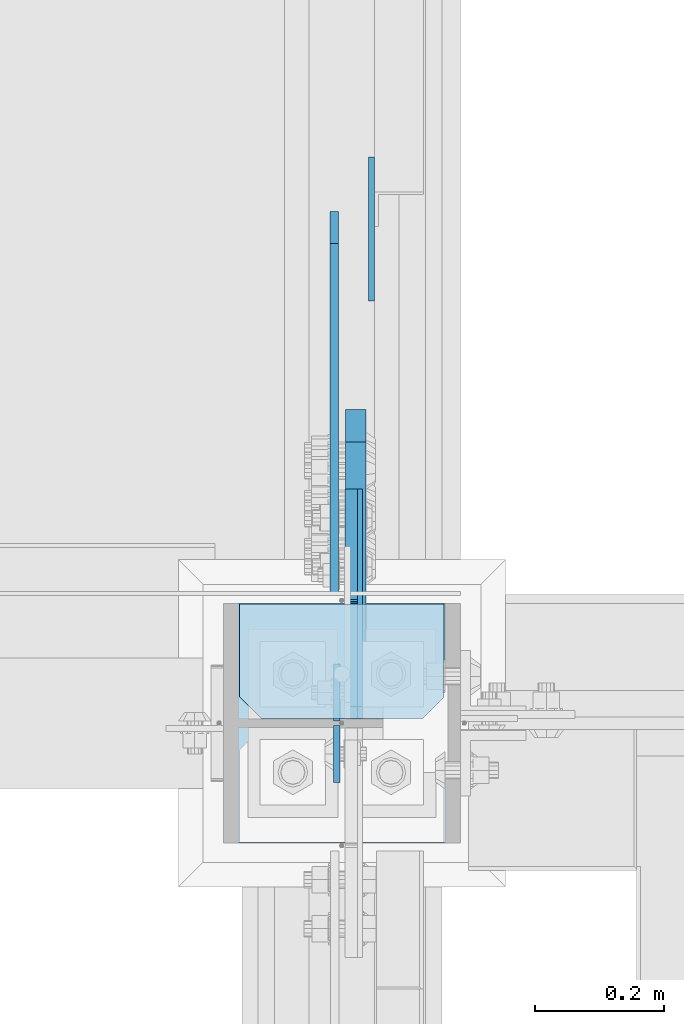
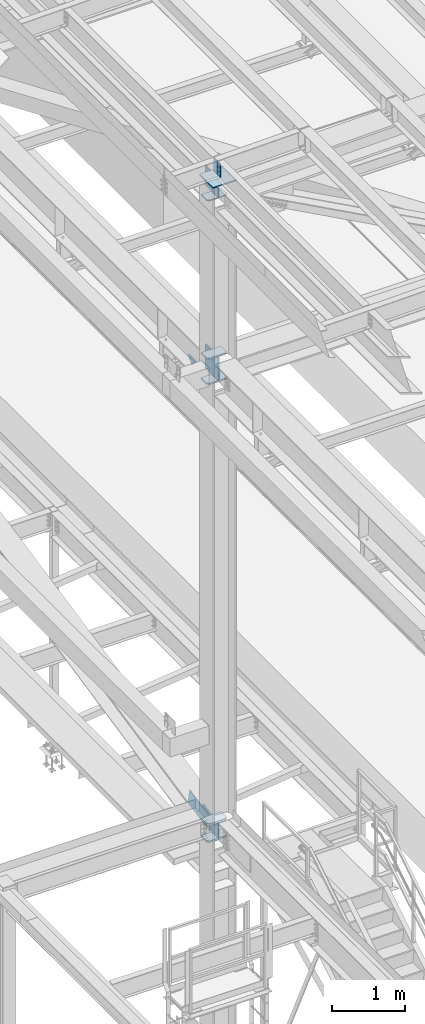
# One storey, part 3209 of 3843: 13 plates, 4 elements without a shape of their own.
"""IFC2X3 building model written with IfcOpenShell, lengths in millimetres."""

from ifc_helpers import new_model, si_unit, frame, origin_with_axes, place, context, subcontext, project, spatial, faceted_brep, material, type_object, element, aggregate, save


model = new_model("IFC2X3")

# Units and contexts
model_context = context("Model", 3, precision=1e-05, world=origin_with_axes())
body_context = subcontext(model_context, "Body", "Model", "MODEL_VIEW")
ifc_project = project(units=[si_unit("LENGTHUNIT", "METRE", prefix="MILLI"), si_unit("AREAUNIT", "SQUARE_METRE"), si_unit("VOLUMEUNIT", "CUBIC_METRE"), si_unit("MASSUNIT", "GRAM", prefix="KILO"), si_unit("TIMEUNIT", "SECOND"), si_unit("PLANEANGLEUNIT", "RADIAN"), si_unit("SOLIDANGLEUNIT", "STERADIAN"), si_unit("THERMODYNAMICTEMPERATUREUNIT", "DEGREE_CELSIUS"), si_unit("LUMINOUSINTENSITYUNIT", "LUMEN")], contexts=[model_context])

# Site, building, storey
site_placement = place(None, origin_with_axes())
site = spatial("IfcSite", under=ifc_project, at=site_placement, CompositionType="ELEMENT")
building_placement = place(site_placement, origin_with_axes())
building = spatial("IfcBuilding", under=site, at=building_placement, Name="Undefined", CompositionType="ELEMENT")
storey_placement = place(building_placement, origin_with_axes())
storey = spatial("IfcBuildingStorey", under=building, at=storey_placement, Name="Undefined", CompositionType="ELEMENT", Elevation=0.0)

# Assembly, plates
assembly_1_placement = place(storey_placement, origin_with_axes())
assembly_1 = element("IfcElementAssembly", 1, at=assembly_1_placement, inside=storey, Name="COLUMN", AssemblyPlace="NOTDEFINED", PredefinedType="RIGID_FRAME")
ifc_material = material(Name="STEEL/A572-50")
plate_type_1 = type_object("IfcPlateType", PredefinedType="NOTDEFINED")
plate_1_placement = place(assembly_1_placement, frame((36734.75, 34030.44375, 42005.249987793), z_axis=(-1.0, 0.0, 0.0), x_axis=(0.0, -1.0, 0.0)))
plate_1 = element("IfcPlate", 2, at=plate_1_placement, type_object=plate_type_1, material=ifc_material, Name="PLATE", context=body_context, shape_type="Brep", body=[
    faceted_brep([(0.0, -12.6999999999971, 0.0), (0.0, -12.7000000020344, 317.500000001608), (0.0, 12.6999999977998, 317.500000001586), (0.0, 12.6999999999971, 0.0), (144.462501525879, -12.6999999999971, 317.5), (144.462501525879, 12.6999999999971, 317.5), (177.800003051758, -12.6999999999971, 284.162498474121), (177.800003051758, 12.6999999999971, 284.162498474121), (177.800003051758, -12.6999999999971, 33.3375015258789), (177.800003051758, 12.6999999999971, 33.3375015258789), (144.462501525879, -12.6999999999971, 0.0), (144.462501525879, 12.6999999999971, 0.0)], [[[0, 1, 2, 3]], [[1, 4, 5, 2]], [[4, 6, 7, 5]], [[6, 8, 9, 7]], [[8, 10, 11, 9]], [[10, 0, 3, 11]], [[5, 7, 9, 11, 3, 2]], [[10, 8, 6, 4, 1, 0]]]),
])
plate_2_placement = place(assembly_1_placement, frame((36734.75, 34030.44375, 42424.35), z_axis=(-1.0, 0.0, 0.0), x_axis=(0.0, -1.0, 0.0)))
plate_2 = element("IfcPlate", 3, at=plate_2_placement, type_object=plate_type_1, material=ifc_material, Name="PLATE", context=body_context, shape_type="Brep", body=[
    faceted_brep([(0.0, -12.6999999999971, 0.0), (0.0, -12.7000000020344, 317.500000001608), (0.0, 12.6999999977998, 317.500000001586), (0.0, 12.6999999999971, 0.0), (144.462501525879, -12.6999999999971, 317.5), (144.462501525879, 12.6999999999971, 317.5), (177.800003051758, -12.6999999999971, 284.162498474121), (177.800003051758, 12.6999999999971, 284.162498474121), (177.800003051758, -12.6999999999971, 33.3375015258789), (177.800003051758, 12.6999999999971, 33.3375015258789), (144.462501525879, -12.6999999999971, 0.0), (144.462501525879, 12.6999999999971, 0.0)], [[[0, 1, 2, 3]], [[1, 4, 5, 2]], [[4, 6, 7, 5]], [[6, 8, 9, 7]], [[8, 10, 11, 9]], [[10, 0, 3, 11]], [[5, 7, 9, 11, 3, 2]], [[10, 8, 6, 4, 1, 0]]]),
])
plate_type_2 = type_object("IfcPlateType", PredefinedType="NOTDEFINED")
plate_3_placement = place(assembly_1_placement, frame((36595.0499999046, 33852.64375, 42411.65), z_axis=(0.0, 1.0, 0.0), x_axis=(0.0, 0.0, -1.0)))
plate_3 = element("IfcPlate", 4, at=plate_3_placement, type_object=plate_type_2, material=ifc_material, Name="PLATE", context=body_context, shape_type="Brep", body=[
    faceted_brep([(0.0, -12.6999999999971, 19.0499992370605), (0.0, -12.6999999999971, 356.393737792969), (0.0, 12.6999999999971, 356.393737792969), (0.0, 12.6999999999971, 19.0499992370605), (393.700012207031, -12.6999999999971, 356.393737792969), (393.700012207031, 12.6999999999971, 356.393737792969), (393.700012207031, -12.6999999999971, 19.0499992370605), (393.700012207031, 12.6999999999971, 19.0499992370605), (374.650012969971, -12.6999999999971, 0.0), (374.650012969971, 12.6999999999971, 0.0), (19.0500015258731, -12.6999999999971, -6.33008312433958e-10), (19.0500015258731, 12.6999999999971, 0.0)], [[[0, 1, 2, 3]], [[1, 4, 5, 2]], [[4, 6, 7, 5]], [[6, 8, 9, 7]], [[8, 10, 11, 9]], [[10, 0, 3, 11]], [[5, 7, 9, 11, 3, 2]], [[10, 8, 6, 4, 1, 0]]]),
])

assembly_2_placement = place(storey_placement, origin_with_axes())
assembly_2 = element("IfcElementAssembly", 5, at=assembly_2_placement, inside=storey, Name="BEAM", AssemblyPlace="NOTDEFINED", PredefinedType="RIGID_FRAME")
plate_type_3 = type_object("IfcPlateType", PredefinedType="NOTDEFINED")
plate_4_placement = place(assembly_2_placement, frame((36568.0624999265, 33848.675, 45691.4946293682), z_axis=(0.0, 1.0, 0.0), x_axis=(0.0, 0.0, -1.0)))
plate_4 = element("IfcPlate", 6, at=plate_4_placement, type_object=plate_type_3, material=ifc_material, Name="PLATE", context=body_context, shape_type="Brep", body=[
    faceted_brep([(0.0, -4.76249999999709, 0.0), (0.0, -4.76249999999709, 88.9000015258789), (0.0, 4.76249999999709, 88.9000015258789), (0.0, 4.76249999999709, 0.0), (228.600006102781, -4.7625000004191, 88.9000015257589), (228.600006102781, 4.76249999954598, 88.9000015257443), (228.600006103079, -4.7625000004482, 7.27595761418343e-12), (228.600006103079, 4.76249999954598, -7.27595761418343e-12)], [[[0, 1, 2, 3]], [[1, 4, 5, 2]], [[4, 6, 7, 5]], [[6, 0, 3, 7]], [[5, 7, 3, 2]], [[6, 4, 1, 0]]]),
])
plate_5_placement = place(assembly_2_placement, frame((36568.062499923, 33842.325, 45691.4946293681), z_axis=(0.0, -1.0, 0.0), x_axis=(0.0, 0.0, -1.0)))
plate_5 = element("IfcPlate", 7, at=plate_5_placement, type_object=plate_type_3, material=ifc_material, Name="PLATE", context=body_context, shape_type="Brep", body=[
    faceted_brep([(0.0, -4.76249999999709, 0.0), (0.0, -4.76249999999709, 88.9000015258789), (0.0, 4.76249999999709, 88.9000015258789), (0.0, 4.76249999999709, 0.0), (228.600006102781, -4.7625000004191, 88.9000015257589), (228.600006102781, 4.76249999954598, 88.9000015257443), (228.600006103079, -4.7625000004482, 7.27595761418343e-12), (228.600006103079, 4.76249999954598, -7.27595761418343e-12)], [[[0, 1, 2, 3]], [[1, 4, 5, 2]], [[4, 6, 7, 5]], [[6, 0, 3, 7]], [[5, 7, 3, 2]], [[6, 4, 1, 0]]]),
])
aggregate(assembly_2, [plate_4, plate_5])

# Plate
plate_type_4 = type_object("IfcPlateType", PredefinedType="NOTDEFINED")
plate_6_placement = place(assembly_1_placement, frame((36734.75, 34030.44375, 45059.5999999991), z_axis=(-1.0, 0.0, 0.0), x_axis=(0.0, -1.0, 0.0)))
plate_6 = element("IfcPlate", 8, at=plate_6_placement, type_object=plate_type_4, material=ifc_material, Name="PLATE", context=body_context, shape_type="Brep", body=[
    faceted_brep([(0.0, -9.52500000000146, 0.0), (0.0, -9.52500000000146, 317.5), (0.0, 9.52500000000146, 317.5), (0.0, 9.52500000000146, 0.0), (144.462501525879, -9.52500000000146, 317.5), (144.462501525879, 9.52500000000146, 317.5), (177.800003051758, -9.52500000000146, 284.162498474121), (177.800003051758, 9.52500000000146, 284.162498474121), (177.800003051758, -9.52500000000146, 33.3375015258789), (177.800003051758, 9.52500000000146, 33.3375015258789), (144.462501525879, -9.52500000000146, 0.0), (144.462501525879, 9.52500000000146, 0.0)], [[[0, 1, 2, 3]], [[1, 4, 5, 2]], [[4, 6, 7, 5]], [[6, 8, 9, 7]], [[8, 10, 11, 9]], [[10, 0, 3, 11]], [[5, 7, 9, 11, 3, 2]], [[10, 8, 6, 4, 1, 0]]]),
])

plate_type_5 = type_object("IfcPlateType", PredefinedType="NOTDEFINED")
plate_7_placement = place(assembly_1_placement, frame((36734.75, 34030.44375, 34382.9984404657), z_axis=(-1.0, 0.0, 0.0), x_axis=(0.0, -1.0, 0.0)))
plate_7 = element("IfcPlate", 9, at=plate_7_placement, type_object=plate_type_5, material=ifc_material, Name="PLATE", context=body_context, shape_type="Brep", body=[
    faceted_brep([(0.0, -15.875, 0.0), (0.0, -15.875, 317.5), (0.0, 15.875, 317.5), (0.0, 15.875, 0.0), (144.462498511086, -15.874999999156, 317.499999999665), (144.462498511086, 15.875000000844, 317.499999999578), (177.800000033079, -15.8749999992506, 284.162498473786), (177.800000033079, 15.8750000007494, 284.162498473699), (177.800000003888, -15.8749999999054, 33.3375015259226), (177.800000003888, 15.8750000000946, 33.3375015258353), (144.462498474124, -15.875, 0.0), (144.462498474124, 15.875, 0.0)], [[[0, 1, 2, 3]], [[1, 4, 5, 2]], [[4, 6, 7, 5]], [[6, 8, 9, 7]], [[8, 10, 11, 9]], [[10, 0, 3, 11]], [[5, 7, 9, 11, 3, 2]], [[10, 8, 6, 4, 1, 0]]]),
])

plate_8_placement = place(assembly_1_placement, frame((36734.75, 34030.44375, 34668.7707446019), z_axis=(-1.0, 0.0, 0.0), x_axis=(0.0, -1.0, 0.0)))
plate_8 = element("IfcPlate", 10, at=plate_8_placement, type_object=plate_type_5, material=ifc_material, Name="PLATE", context=body_context, shape_type="Brep", body=[
    faceted_brep([(0.0, -15.875, 0.0), (0.0, -15.875, 317.5), (0.0, 15.875, 317.5), (0.0, 15.875, 0.0), (144.462498511086, -15.874999999156, 317.499999999665), (144.462498511086, 15.875000000844, 317.499999999578), (177.800000033079, -15.8749999992506, 284.162498473786), (177.800000033079, 15.8750000007494, 284.162498473699), (177.800000003888, -15.8749999999054, 33.3375015259226), (177.800000003888, 15.8750000000946, 33.3375015258353), (144.462498474124, -15.875, 0.0), (144.462498474124, 15.875, 0.0)], [[[0, 1, 2, 3]], [[1, 4, 5, 2]], [[4, 6, 7, 5]], [[6, 8, 9, 7]], [[8, 10, 11, 9]], [[10, 0, 3, 11]], [[5, 7, 9, 11, 3, 2]], [[10, 8, 6, 4, 1, 0]]]),
])

# Assembly, plate
assembly_3_placement = place(storey_placement, origin_with_axes())
assembly_3 = element("IfcElementAssembly", 11, at=assembly_3_placement, inside=storey, Name="BEAM", AssemblyPlace="NOTDEFINED", PredefinedType="RIGID_FRAME")
plate_type_6 = type_object("IfcPlateType", PredefinedType="NOTDEFINED")
plate_9_placement = place(assembly_3_placement, frame((36622.0375, 34501.7289773786, 41925.875), z_axis=(0.0, 0.707106781186548, 0.707106781186548), x_axis=(5.70000238222118e-08, 0.707106781186546, -0.707106781186546)))
plate_9 = element("IfcPlate", 12, at=plate_9_placement, type_object=plate_type_6, material=ifc_material, Name="PLATE", context=body_context, shape_type="Brep", body=[
    faceted_brep([(0.0, -4.76249999999709, 0.0), (157.726597423803, -4.76249999999709, 157.726601438866), (157.726597423803, 4.76249999999709, 157.726601438866), (0.0, 4.76249999999709, 0.0), (188.387110059113, -4.76249999999709, 127.066089584019), (188.387110059113, 4.76249999999709, 127.066089584019), (188.387111679331, -4.76249999999709, 1.09139364212751e-10), (188.387111679331, 4.76249999999709, 1.09139364212751e-10)], [[[0, 1, 2, 3]], [[1, 4, 5, 2]], [[4, 6, 7, 5]], [[6, 0, 3, 7]], [[5, 7, 3, 2]], [[6, 4, 1, 0]]]),
])
aggregate(assembly_3, [plate_9])

# Plate
plate_type_7 = type_object("IfcPlateType", PredefinedType="NOTDEFINED")
plate_10_placement = place(assembly_1_placement, frame((36760.15, 33659.7625, 45408.1254169701), z_axis=(-1.0, 0.0, 0.0), x_axis=(0.0, 1.0, 0.0)))
plate_10 = element("IfcPlate", 13, at=plate_10_placement, type_object=plate_type_7, material=ifc_material, Name="PLATE", context=body_context, shape_type="Brep", body=[
    faceted_brep([(0.0, -9.52500000000146, 0.0), (0.0, -9.52500000015425, 368.299999993164), (0.0, 9.52499999984866, 368.299999993018), (0.0, 9.52500000000146, 0.0), (371.474999999991, -9.52500000015425, 368.299999993149), (371.474999999991, 9.52499999984866, 368.299999993003), (371.474999999991, -9.52500000000146, 4.36557456851006e-11), (371.474999999991, 9.52500000000873, -7.27595761418343e-11)], [[[0, 1, 2, 3]], [[1, 4, 5, 2]], [[4, 6, 7, 5]], [[6, 0, 3, 7]], [[5, 7, 3, 2]], [[6, 4, 1, 0]]]),
])

plate_type_8 = type_object("IfcPlateType", PredefinedType="NOTDEFINED")
plate_11_placement = place(assembly_1_placement, frame((36590.2875003929, 33852.64375, 45088.1750026614), z_axis=(0.0, 0.707106781186548, 0.707106781186548), x_axis=(5.70000238222118e-08, 0.707106781186546, -0.707106781186546)))
plate_11 = element("IfcPlate", 14, at=plate_11_placement, type_object=plate_type_8, material=ifc_material, Name="PLATE", context=body_context, shape_type="Brep", body=[
    faceted_brep([(0.0, -9.52500000000146, 0.0), (-205.423360299239, -9.52500000000146, 205.423357237712), (-205.423360299239, 9.52500000000146, 205.423357237712), (0.0, 9.52500000000146, 0.0), (-205.423360299126, -9.52500000000146, 232.3641254002), (-205.423360299126, 9.52500000000146, 232.3641254002), (-92.608892539698, -9.52500000000146, 345.178591747157), (-92.608892539698, 9.52500000000146, 345.178591747157), (-89.0037379960995, -9.52500000000146, 342.769704533581), (-89.0037379960995, 9.52500000000146, 342.769704533581), (-84.751168274659, -9.52500000000146, 341.923815855786), (-84.751168274659, 9.52500000000146, 341.923815855786), (-80.4985985658241, -9.52500000000146, 342.769704596954), (-80.4985985658241, 9.52500000000146, 342.769704596954), (-76.8934440581252, -9.52500000000146, 345.178591864264), (-76.8934440581252, 9.52500000000146, 345.178591864264), (40.9724185538689, -9.52500000000146, 463.044456243078), (40.9724185538689, 9.52500000000146, 463.044456243078), (265.478821579974, -9.52500000000146, 238.538053217882), (265.478821579974, 9.52500000000146, 238.538053217882), (26.9407683632344, -9.52499999999964, 2.03726813197136e-10), (26.9407683632344, 9.52499999999964, 2.03726813197136e-10)], [[[0, 1, 2, 3]], [[1, 4, 5, 2]], [[4, 6, 7, 5]], [[6, 8, 9, 7]], [[8, 10, 11, 9]], [[10, 12, 13, 11]], [[12, 14, 15, 13]], [[14, 16, 17, 15]], [[16, 18, 19, 17]], [[18, 20, 21, 19]], [[20, 0, 3, 21]], [[5, 7, 9, 11, 13, 15, 17, 19, 21, 3, 2]], [[20, 18, 16, 14, 12, 10, 8, 6, 4, 1, 0]]]),
])

# Assembly, plate
assembly_4_placement = place(storey_placement, origin_with_axes())
assembly_4 = element("IfcElementAssembly", 15, at=assembly_4_placement, inside=storey, Name="BEAM", AssemblyPlace="NOTDEFINED", PredefinedType="RIGID_FRAME")
plate_type_9 = type_object("IfcPlateType", PredefinedType="NOTDEFINED")
plate_12_placement = place(assembly_4_placement, frame((36564.09375, 34590.503093171, 34764.874181181), z_axis=(0.0, -0.978105929080115, -0.208107644017044), x_axis=(0.0, 0.208107644017047, -0.978105929080115)))
plate_12 = element("IfcPlate", 16, at=plate_12_placement, type_object=plate_type_9, material=ifc_material, Name="PLATE", context=body_context, shape_type="Brep", body=[
    faceted_brep([(0.0, -6.3499999046162, 0.0), (-1.27693056128919e-09, -6.34999999999854, 558.800000006726), (0.0, 6.35000000000036, 558.799999999988), (7.27595761418343e-12, 6.3499999046162, 0.0), (241.299987796625, -6.34999999999854, 610.140423592369), (241.299987796625, 6.34999999999854, 610.140423592369), (241.300003051758, -6.34999999999854, 0.0), (241.300003051758, 6.34999999999854, 0.0)], [[[0, 1, 2, 3]], [[1, 4, 5, 2]], [[4, 6, 7, 5]], [[6, 0, 3, 7]], [[5, 7, 3, 2]], [[6, 4, 1, 0]]]),
])
aggregate(assembly_4, [plate_12])

# Plate
plate_type_10 = type_object("IfcPlateType", PredefinedType="NOTDEFINED")
plate_13_placement = place(assembly_1_placement, frame((36597.43125, 33852.6437499999, 34652.8957445818), z_axis=(0.0, 1.0, 0.0), x_axis=(0.0, 0.0, -1.0)))
plate_13 = element("IfcPlate", 17, at=plate_13_placement, type_object=plate_type_10, material=ifc_material, Name="PLATE", context=body_context, shape_type="Brep", body=[
    faceted_brep([(254.022308349609, -15.875, 28.5749999999971), (0.0, -15.875, 28.5750007629395), (0.0, -6.34999999999854, 19.0499992370605), (19.0500015258731, 12.6999999999971, 0.0), (234.972309112549, 12.6999999999971, 0.0), (254.022308349609, -6.34999923706346, 19.0499992370605), (0.0, -15.875, 210.224574274944), (0.0, 15.875, 210.224574274944), (0.0, 15.875, 19.0499992370605), (-0.0174382124168915, -15.875, 210.889876084271), (-0.0174382124168915, 15.875, 210.889876084271), (-0.0697049612790579, -15.875, 211.553350858252), (-0.0697049612790579, 15.875, 211.553350858252), (-0.156656712941185, -15.875, 212.213176578902), (-0.156656712941185, 15.875, 212.213176578902), (-0.278054682654329, -15.875, 212.867541249172), (-0.278054682654329, 15.875, 212.867541249172), (-46.3924865722656, -15.875, 429.605377197266), (-46.3924865722656, 15.875, 429.605377197266), (189.624465942383, -15.875, 479.821746826172), (189.624465942383, 15.875, 479.821746826172), (253.744253627483, -15.875, 178.458758379813), (253.744253627483, 15.875, 178.458758379813), (253.865651614389, -15.875, 177.804393664526), (253.865651614389, 15.875, 177.804393664526), (253.952603378406, -15.875, 177.144567897696), (253.952603378406, 15.875, 177.144567897696), (254.004870134711, -15.875, 176.481093076756), (254.004870134711, 15.875, 176.481093076756), (254.022308349609, -15.875, 175.815791220077), (254.022308349609, 15.875, 175.815791220077), (254.022308349609, 15.875, 19.0499992370605), (234.972309112549, 15.875, 0.0), (19.0500015258804, 15.875, 0.0)], [[[0, 1, 2, 3, 4, 5]], [[6, 7, 8, 2, 1]], [[6, 9, 10, 7]], [[9, 11, 12, 10]], [[11, 13, 14, 12]], [[13, 15, 16, 14]], [[15, 17, 18, 16]], [[17, 19, 20, 18]], [[19, 21, 22, 20]], [[21, 23, 24, 22]], [[23, 25, 26, 24]], [[25, 27, 28, 26]], [[27, 29, 30, 28]], [[31, 30, 29, 0, 5]], [[32, 31, 5, 4]], [[33, 32, 4, 3]], [[8, 33, 3, 2]], [[10, 12, 14, 16, 18, 20, 22, 24, 26, 28, 30, 31, 32, 33, 8, 7]], [[29, 27, 25, 23, 21, 19, 17, 15, 13, 11, 9, 6, 1, 0]]]),
])

aggregate(assembly_1, [plate_10, plate_1, plate_2, plate_3, plate_6, plate_11, plate_13, plate_7, plate_8])

save(model, "model.ifc")
